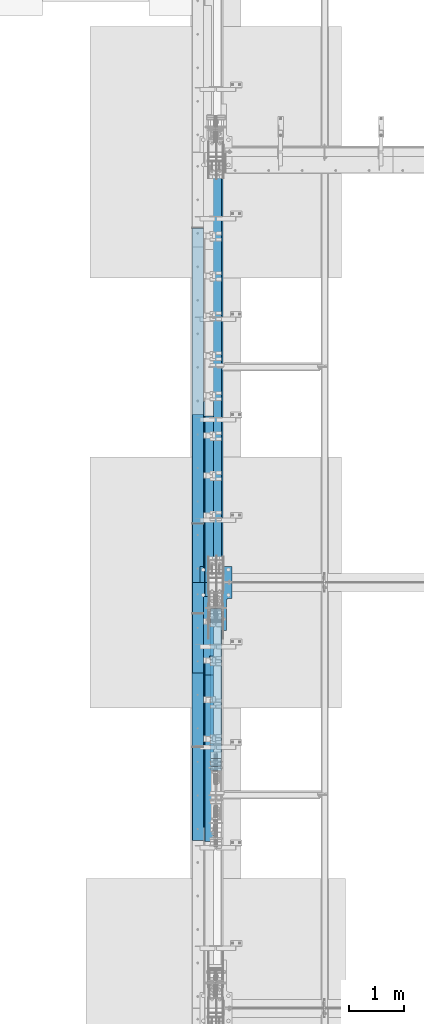
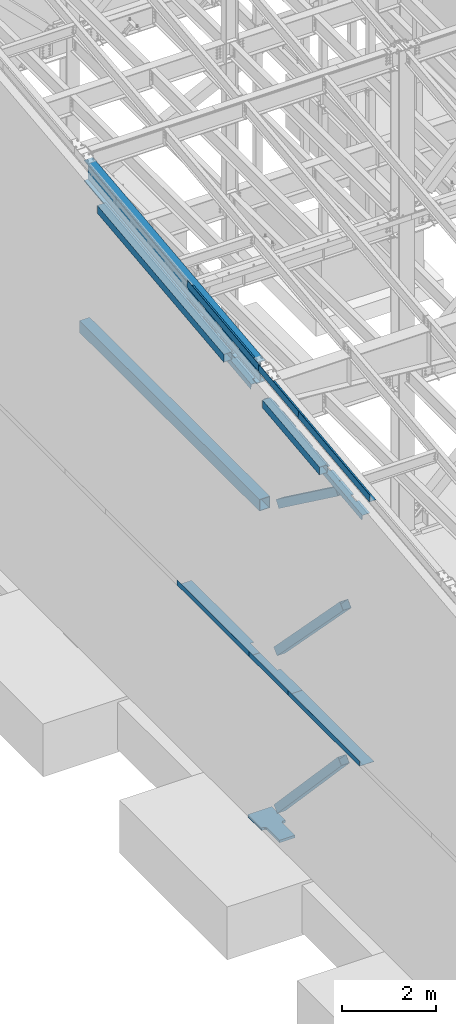
# One storey, part 725 of 1179: 14 beams, 3 members, 11 elements without a shape of their own.
"""IFC2X3 building model written with IfcOpenShell, lengths in millimetres."""

import ifcopenshell
import ifcopenshell.guid

model = None  # the IFC model being written
_history = None  # IfcOwnerHistory: only IFC2X3 demands one
_inside = {}  # id of a spatial element -> (the spatial element, [elements in it])
_under = {}  # id of a project, library or spatial element -> (it, [spatial elements below it])
_declared = {}  # id of a project -> (the project, [libraries it declares])
_typed = {}  # id of a type object -> (the type object, [elements of that type])
_made_of = {}  # id of a material, layer set ... -> (it, [elements and type objects made of it])


def new_model(schema):
    """Start an empty IFC model of exactly this schema.

    Asked for "IFC4X3", IfcOpenShell would pick the latest addendum, in which some entities
    have other attributes; the version numbers below select the first issue.
    IFC2X3 requires an IfcOwnerHistory on every rooted entity: one is made here for all.
    """
    global model, _history
    if schema == "IFC4X3":
        model = ifcopenshell.file(schema_version=(4, 3, 0, 0))
    else:
        model = ifcopenshell.file(schema=schema)
    _inside.clear()
    _under.clear()
    _declared.clear()
    _typed.clear()
    _made_of.clear()
    _history = None
    if model.schema == "IFC2X3":
        org = make("IfcOrganization", Name="unknown")
        user = make(
            "IfcPersonAndOrganization",
            ThePerson=make("IfcPerson", FamilyName="unknown"),
            TheOrganization=org,
        )
        app = make(
            "IfcApplication",
            ApplicationDeveloper=org,
            Version="unknown",
            ApplicationFullName="unknown",
            ApplicationIdentifier="unknown",
        )
        _history = make(
            "IfcOwnerHistory",
            OwningUser=user,
            OwningApplication=app,
            ChangeAction="ADDED",
            CreationDate=0,
        )
    return model


def make(cls, **values):
    """One entity of the class cls with the attributes given. An attribute that is None is left unset."""
    return model.create_entity(
        cls, **{name: value for name, value in values.items() if value is not None}
    )


def rooted(cls, **values):
    """An entity with a GlobalId (a new one), such as an element, a storey or a relation."""
    return make(cls, GlobalId=ifcopenshell.guid.new(), OwnerHistory=_history, **values)


def si_unit(unit_type, name, prefix=None):
    """IfcSIUnit, for example si_unit("LENGTHUNIT", "METRE", prefix="MILLI")."""
    return make("IfcSIUnit", UnitType=unit_type, Prefix=prefix, Name=name)


def assignment(units):
    """IfcUnitAssignment: the units of a project."""
    return None if units is None else make("IfcUnitAssignment", Units=units)


def point(xyz):
    """IfcCartesianPoint."""
    return None if xyz is None else make("IfcCartesianPoint", Coordinates=xyz)


def direction(xyz):
    """IfcDirection."""
    return None if xyz is None else make("IfcDirection", DirectionRatios=xyz)


def frame(location, z_axis=None, x_axis=None):
    """IfcAxis2Placement3D, a coordinate frame: its origin and axes. An axis left out is left unset."""
    return make(
        "IfcAxis2Placement3D",
        Location=point(location),
        Axis=direction(z_axis),
        RefDirection=direction(x_axis),
    )


def origin_with_axes():
    """The frame at (0, 0, 0) with the z axis (0, 0, 1) and the x axis (1, 0, 0) written out."""
    return frame((0.0, 0.0, 0.0), z_axis=(0.0, 0.0, 1.0), x_axis=(1.0, 0.0, 0.0))


def place(relative_to, where):
    """IfcLocalPlacement: puts the frame where relative to a parent placement (None: the world)."""
    return make(
        "IfcLocalPlacement", PlacementRelTo=relative_to, RelativePlacement=where
    )


def context(
    kind, dimensions, precision=None, world=None, true_north=None, identifier=None
):
    """IfcGeometricRepresentationContext, for example the 3D "Model" context."""
    return make(
        "IfcGeometricRepresentationContext",
        ContextIdentifier=identifier,
        ContextType=kind,
        CoordinateSpaceDimension=dimensions,
        Precision=precision,
        WorldCoordinateSystem=world,
        TrueNorth=true_north,
    )


def subcontext(parent, identifier, kind, view, scale=None):
    """IfcGeometricRepresentationSubContext, for example "Body" below "Model"."""
    return make(
        "IfcGeometricRepresentationSubContext",
        ContextIdentifier=identifier,
        ContextType=kind,
        ParentContext=parent,
        TargetScale=scale,
        TargetView=view,
    )


def project(units=None, contexts=None):
    """IfcProject with its units and contexts."""
    return rooted(
        "IfcProject",
        Name="project",
        RepresentationContexts=contexts,
        UnitsInContext=assignment(units),
    )


def spatial(cls, under=None, at=None, **own):
    """A site, building, storey or space (cls), placed at a placement, below another one or the project."""
    s = rooted(cls, ObjectPlacement=at, **own)
    if under is not None:
        _under.setdefault(under.id(), (under, []))[1].append(s)
    return s


def faces_of(points, faces, orient=None, outer=None):
    """IfcFace entities. A face is a list of loops; a loop is a list of indices into points, from 0.

    orient and outer hold one flag for each loop. By default every Orientation is true, the
    first loop of a face is its IfcFaceOuterBound and the others are IfcFaceBound.
    """
    made = []
    for i, loops in enumerate(faces):
        bounds = []
        for j, loop in enumerate(loops):
            is_outer = j == 0 if outer is None else outer[i][j]
            bounds.append(
                make(
                    "IfcFaceOuterBound" if is_outer else "IfcFaceBound",
                    Bound=make("IfcPolyLoop", Polygon=[points[k] for k in loop]),
                    Orientation=True if orient is None else orient[i][j],
                )
            )
        made.append(make("IfcFace", Bounds=bounds))
    return made


def faceted_brep(points, faces, orient=None, outer=None, voids=None):
    """IfcFacetedBrep: a solid bounded by flat faces; with voids (closed shells), ...WithVoids."""
    shared = [point(p) for p in points]
    hull = make("IfcClosedShell", CfsFaces=faces_of(shared, faces, orient, outer))
    if voids is None:
        return make("IfcFacetedBrep", Outer=hull)
    return make(
        "IfcFacetedBrepWithVoids",
        Outer=hull,
        Voids=[
            make(cls, CfsFaces=faces_of(shared, fs, o, b)) for cls, fs, o, b in voids
        ],
    )


def shape(context_of_items, identifier, shape_type, items):
    """IfcShapeRepresentation: the items that make up one representation, for example the "Body"."""
    return make(
        "IfcShapeRepresentation",
        ContextOfItems=context_of_items,
        RepresentationIdentifier=identifier,
        RepresentationType=shape_type,
        Items=items,
    )


def material(Name=None, Category=None):
    """IfcMaterial."""
    return make("IfcMaterial", Name=Name, Category=Category)


def made_of(thing, what):
    """Note that an element or type object is made of a material, layer set ...; save() writes the relation."""
    if what is not None:
        _made_of.setdefault(what.id(), (what, []))[1].append(thing)
    return thing


def type_object(cls, material=None, **own):
    """A type object (cls), such as IfcWallType, which elements share."""
    return made_of(rooted(cls, **own), material)


def element(
    cls,
    number,
    at=None,
    inside=None,
    cuts=None,
    type_object=None,
    material=None,
    context=None,
    identifier="Body",
    shape_type=None,
    held_by="IfcProductDefinitionShape",
    body=None,
    shapes=None,
    **own,
):
    """One element of the class cls, such as IfcWall. Its Tag is "e" and its number.

    at: its placement. inside: the storey or other place that contains it. cuts: it is an
    opening in that element (IfcRelVoidsElement). A single representation is given by context,
    identifier, shape_type and body (its items); several are given by shapes. held_by: the class
    of the entity that holds the representations. save() writes the other relations.
    """
    e = rooted(cls, Tag="e%d" % number, ObjectPlacement=at, **own)
    if body is not None:
        shapes = [shape(context, identifier, shape_type, body)]
    if shapes is not None:
        e.Representation = make(held_by, Representations=shapes)
    if inside is not None:
        _inside.setdefault(inside.id(), (inside, []))[1].append(e)
    if cuts is not None:
        rooted(
            "IfcRelVoidsElement", RelatingBuildingElement=cuts, RelatedOpeningElement=e
        )
    if type_object is not None:
        _typed.setdefault(type_object.id(), (type_object, []))[1].append(e)
    return made_of(e, material)


def aggregate(whole, parts):
    """IfcRelAggregates: a whole, such as a stair, and the parts it consists of."""
    return rooted("IfcRelAggregates", RelatingObject=whole, RelatedObjects=parts)


def save(model, path):
    """Write the relations noted so far, then the file.

    IfcRelAggregates (storeys below a building ...), IfcRelContainedInSpatialStructure (elements
    in a storey), IfcRelDefinesByType, IfcRelAssociatesMaterial and IfcRelDeclares: one each for
    every whole, place, type object, material and project.
    """
    for whole, parts in _under.values():
        aggregate(whole, parts)
    for where, things in _inside.values():
        rooted(
            "IfcRelContainedInSpatialStructure",
            RelatedElements=things,
            RelatingStructure=where,
        )
    for kind, things in _typed.values():
        rooted("IfcRelDefinesByType", RelatedObjects=things, RelatingType=kind)
    for what, things in _made_of.values():
        rooted("IfcRelAssociatesMaterial", RelatedObjects=things, RelatingMaterial=what)
    for by, libraries in _declared.values():
        rooted("IfcRelDeclares", RelatingContext=by, RelatedDefinitions=libraries)
    model.write(path)


model = new_model("IFC2X3")

# Units and contexts
model_context = context("Model", 3, precision=1e-05, world=origin_with_axes())
body_context = subcontext(model_context, "Body", "Model", "MODEL_VIEW")
ifc_project = project(units=[si_unit("LENGTHUNIT", "METRE", prefix="MILLI"), si_unit("AREAUNIT", "SQUARE_METRE"), si_unit("VOLUMEUNIT", "CUBIC_METRE"), si_unit("MASSUNIT", "GRAM", prefix="KILO"), si_unit("TIMEUNIT", "SECOND"), si_unit("PLANEANGLEUNIT", "RADIAN"), si_unit("SOLIDANGLEUNIT", "STERADIAN"), si_unit("THERMODYNAMICTEMPERATUREUNIT", "DEGREE_CELSIUS"), si_unit("LUMINOUSINTENSITYUNIT", "LUMEN")], contexts=[model_context])

# Site, building, storey
site_placement = place(None, origin_with_axes())
site = spatial("IfcSite", under=ifc_project, at=site_placement, CompositionType="ELEMENT")
building_placement = place(site_placement, origin_with_axes())
building = spatial("IfcBuilding", under=site, at=building_placement, Name="Undefined", CompositionType="ELEMENT")
storey_placement = place(building_placement, origin_with_axes())
storey = spatial("IfcBuildingStorey", under=building, at=storey_placement, Name="Undefined", CompositionType="ELEMENT", Elevation=0.0)

# Assembly, beam
assembly_1_placement = place(storey_placement, origin_with_axes())
assembly_1 = element("IfcElementAssembly", 1, at=assembly_1_placement, inside=storey, Name="BEAM", AssemblyPlace="NOTDEFINED", PredefinedType="RIGID_FRAME")
ifc_material_1 = material(Name="STEEL/A36")
beam_type_1 = type_object("IfcBeamType", PredefinedType="NOTDEFINED")
beam_1_placement = place(assembly_1_placement, frame((388.937000000002, 20744.8759537219, 11594.2188079249), z_axis=(0.0, -0.993676146336441, -0.112284087038017), x_axis=(-1.0, 0.0, 0.0)))
beam_1 = element("IfcBeam", 2, at=beam_1_placement, type_object=beam_type_1, material=ifc_material_1, Name="BENT_PLATE", context=body_context, shape_type="Brep", body=[
    faceted_brep([(71.4367508136392, -3.17500000044674, 1106.32825658341), (71.4367849309066, 3.1552417119201, 1106.32795884977), (0.0, 3.17499999954998, 1106.32798145128), (0.0, -3.17500000044674, 1106.32827920303), (71.4368115209303, -3.17499997041341, 1524.00064213012), (71.4368436902772, 3.174999999379, 1523.99999999914), (153.98700000004, -3.17499999938263, -1523.99999999915), (0.0, -3.17499999999927, -1524.0), (0.0, 3.17499999999927, -1524.0), (160.33700000004, 3.17500000061409, -1523.99999999915), (160.337000000008, -187.324999998866, -1523.99999999923), (153.987000000008, -187.324999998866, -1523.99999999923), (160.336999999976, 3.174999999379, 1523.99999999915), (160.337000000008, -187.325000000099, 1523.99999999907), (153.987000000008, -187.325000000099, 1523.99999999907), (153.986999999976, -3.17500000061773, 1523.99999999914)], [[[0, 1, 2, 3]], [[4, 5, 1, 0]], [[6, 7, 8, 9, 10, 11]], [[9, 12, 13, 10]], [[14, 11, 10, 13]], [[15, 6, 11, 14]], [[3, 7, 6, 15, 4, 0]], [[8, 7, 3, 2]], [[12, 9, 8, 2, 1, 5]], [[15, 14, 13, 12, 5, 4]]]),
])

# Assembly, beams
assembly_2_placement = place(storey_placement, origin_with_axes())
assembly_2 = element("IfcElementAssembly", 3, at=assembly_2_placement, inside=storey, Name="BEAM", AssemblyPlace="NOTDEFINED", PredefinedType="RIGID_FRAME")
beam_2_placement = place(assembly_2_placement, frame((388.937000043229, 18382.5389240182, 11327.277855736), z_axis=(0.0, -0.993676146336441, -0.112284087038017), x_axis=(-1.0, 0.0, 0.0)))
beam_2 = element("IfcBeam", 4, at=beam_2_placement, type_object=beam_type_1, material=ifc_material_1, Name="BENT_PLATE", context=body_context, shape_type="Brep", body=[
    faceted_brep([(71.4368100497966, -3.17499999982647, -431.111032670688), (71.4368442882297, 3.17447798306421, -431.11102991645), (71.4367344368292, 3.17500000033942, -846.931499999526), (71.4367001974234, -3.1749999996573, -846.931499999529), (5.00222085975111e-12, -3.17499999982647, -431.111009274173), (5.00222085975111e-12, 3.17500000017026, -431.111006519772), (160.336999998218, 3.17499999965366, 846.931499999526), (-9.77706804405898e-12, 3.17499999965366, 846.931499999522), (-9.77706804405898e-12, -3.17500000034306, 846.931499999522), (153.986999998218, -3.17500000034306, 846.931499999522), (153.986999998236, -187.324999998071, 846.931499999449), (160.336999998236, -187.324999998071, 846.931499999449), (160.336999998254, 3.17500000033942, -846.931499999522), (160.336999998236, -187.324999997387, -846.931499999599), (153.986999998236, -187.324999997387, -846.931499999599), (153.986999998254, -3.1749999996573, -846.931499999529)], [[[0, 1, 2, 3]], [[4, 5, 1, 0]], [[6, 7, 8, 9, 10, 11]], [[12, 6, 11, 13]], [[10, 14, 13, 11]], [[9, 15, 14, 10]], [[12, 13, 14, 15, 3, 2]], [[7, 6, 12, 2, 1, 5]], [[8, 7, 5, 4]], [[15, 9, 8, 4, 0, 3]]]),
])
beam_3_placement = place(assembly_2_placement, frame((388.937000000002, 16026.6008477543, 11061.0599768286), z_axis=(0.0, -0.993676146336441, -0.112284087038017), x_axis=(-1.0, 0.0, 0.0)))
beam_3 = element("IfcBeam", 5, at=beam_3_placement, type_object=beam_type_1, material=ifc_material_1, Name="BENT_PLATE", context=body_context, shape_type="Brep", body=[
    faceted_brep([(0.0, -3.17499999999927, -1524.0), (6.00266503170133e-10, -3.17499999922438, 1524.00000000052), (6.00266503170133e-10, 3.17500000077416, 1524.00000000052), (0.0, 3.17499999999927, -1524.0), (160.336999999976, 3.174999999379, 1523.99999999915), (160.33700000004, 3.17500000061409, -1523.99999999915), (153.98700000004, -3.17499999938263, -1523.99999999915), (153.986999999976, -3.17500000061773, 1523.99999999914), (160.337000000008, -187.325000000099, 1523.99999999907), (160.337000000008, -187.324999998866, -1523.99999999923), (153.987000000008, -187.325000000099, 1523.99999999907), (153.987000000008, -187.324999998866, -1523.99999999923)], [[[0, 1, 2, 3]], [[3, 2, 4, 5]], [[1, 0, 6, 7]], [[5, 4, 8, 9]], [[4, 2, 1, 7, 10, 8]], [[7, 6, 11, 10]], [[6, 0, 3, 5, 9, 11]], [[10, 11, 9, 8]]]),
])

# Assembly, member
assembly_3_placement = place(storey_placement, origin_with_axes())
assembly_3 = element("IfcElementAssembly", 6, at=assembly_3_placement, inside=storey, Name="None", AssemblyPlace="NOTDEFINED", PredefinedType="RIGID_FRAME")
ifc_material_2 = material(Name="STEEL/A992")
member_type = type_object("IfcMemberType", Name="HSS8X8X3/16", PredefinedType="NOTDEFINED")
member_1_placement = place(assembly_3_placement, frame((431.800000000002, 18595.6807195261, 8325.44875404219), z_axis=(-1.0, 0.0, 0.0), x_axis=(0.0, -0.806043266248582, 0.591856615182527)))
member_1 = element("IfcMember", 7, at=member_1_placement, type_object=member_type, material=ifc_material_2, Name="None", ObjectType="HSS8X8X3/16", context=body_context, shape_type="Brep", body=[
    faceted_brep([(-3.63797880709171e-12, 96.8374999999978, -96.8375000000015), (-3.63797880709171e-12, -96.8374999999978, -96.8375000000015), (3111.50000002446, -96.8375000002598, -96.8375), (3111.50000002456, 96.8374999994812, -96.8375), (-3.63797880709171e-12, -96.8374999999978, 96.8375000000015), (3111.50000002446, -96.8375000002598, 96.8375), (-3.63797880709171e-12, 96.8374999999978, 96.8375000000015), (3111.50000002456, 96.8374999994812, 96.8375), (-3.63797880709171e-12, 101.599999999999, -101.599999999999), (-3.63797880709171e-12, 101.599999999999, 101.599999999999), (3111.50000002456, 101.599999999471, 101.6), (3111.50000002456, 101.599999999471, -101.6), (0.0, -101.599999999999, 101.599999999999), (3111.50000002446, -101.600000000253, 101.6), (0.0, -101.599999999999, -101.599999999999), (3111.50000002446, -101.600000000253, -101.6)], [[[0, 1, 2, 3]], [[1, 4, 5, 2]], [[4, 6, 7, 5]], [[6, 0, 3, 7]], [[8, 9, 10, 11]], [[9, 12, 13, 10]], [[12, 14, 15, 13]], [[14, 8, 11, 15]], [[13, 15, 11, 10], [5, 7, 3, 2]], [[14, 12, 9, 8], [6, 4, 1, 0]]]),
])
aggregate(assembly_3, [member_1])

assembly_4_placement = place(storey_placement, origin_with_axes())
assembly_4 = element("IfcElementAssembly", 8, at=assembly_4_placement, inside=storey, Name="None", AssemblyPlace="NOTDEFINED", PredefinedType="RIGID_FRAME")
member_2_placement = place(assembly_4_placement, frame((431.800000000002, 18683.9850517779, 4449.73744761525), z_axis=(-1.0, 0.0, 0.0), x_axis=(0.0, -0.69846692303685, 0.715642339037759)))
member_2 = element("IfcMember", 9, at=member_2_placement, type_object=member_type, material=ifc_material_2, Name="None", ObjectType="HSS8X8X3/16", context=body_context, shape_type="Brep", body=[
    faceted_brep([(-3.63797880709171e-12, 96.8374999999978, -96.8375000000015), (-3.63797880709171e-12, -96.8374999999978, -96.8375000000015), (4020.12294193522, -96.8374999996613, -96.8375), (4020.12294193534, 96.8375000002416, -96.8375), (-3.63797880709171e-12, -96.8374999999978, 96.8375000000015), (4020.12294193522, -96.8374999996613, 96.8375), (-3.63797880709171e-12, 96.8374999999978, 96.8375000000015), (4020.12294193534, 96.8375000002416, 96.8375), (-3.63797880709171e-12, 101.599999999999, -101.599999999999), (-3.63797880709171e-12, 101.599999999999, 101.599999999999), (4020.12294193534, 101.600000000239, 101.6), (4020.12294193534, 101.600000000239, -101.6), (0.0, -101.599999999999, 101.599999999999), (4020.12294193522, -101.59999999966, 101.6), (0.0, -101.599999999999, -101.599999999999), (4020.12294193522, -101.59999999966, -101.6)], [[[0, 1, 2, 3]], [[1, 4, 5, 2]], [[4, 6, 7, 5]], [[6, 0, 3, 7]], [[8, 9, 10, 11]], [[9, 12, 13, 10]], [[12, 14, 15, 13]], [[14, 8, 11, 15]], [[13, 15, 11, 10], [5, 7, 3, 2]], [[14, 12, 9, 8], [6, 4, 1, 0]]]),
])
aggregate(assembly_4, [member_2])

assembly_5_placement = place(storey_placement, origin_with_axes())
assembly_5 = element("IfcElementAssembly", 10, at=assembly_5_placement, inside=storey, Name="None", AssemblyPlace="NOTDEFINED", PredefinedType="RIGID_FRAME")
member_3_placement = place(assembly_5_placement, frame((431.800000000002, 18676.0263469619, 369.341890443129), z_axis=(-1.0, 0.0, 0.0), x_axis=(0.0, -0.68599585875867, 0.727605443744036)))
member_3 = element("IfcMember", 11, at=member_3_placement, type_object=member_type, material=ifc_material_2, Name="None", ObjectType="HSS8X8X3/16", context=body_context, shape_type="Brep", body=[
    faceted_brep([(-3.63797880709171e-12, 96.8374999999978, -96.8375000000015), (-3.63797880709171e-12, -96.8374999999978, -96.8375000000015), (3968.75000001255, -96.8375000016003, -96.8375), (3968.75000001275, 96.8374999981806, -96.8375), (-3.63797880709171e-12, -96.8374999999978, 96.8375000000015), (3968.75000001255, -96.8375000016003, 96.8375), (-3.63797880709171e-12, 96.8374999999978, 96.8375000000015), (3968.75000001275, 96.8374999981806, 96.8375), (-3.63797880709171e-12, 101.599999999999, -101.599999999999), (-3.63797880709171e-12, 101.599999999999, 101.599999999999), (3968.75000001276, 101.599999998176, 101.6), (3968.75000001276, 101.599999998176, -101.6), (0.0, -101.599999999999, 101.599999999999), (3968.75000001255, -101.600000001596, 101.6), (0.0, -101.599999999999, -101.599999999999), (3968.75000001255, -101.600000001596, -101.6)], [[[0, 1, 2, 3]], [[1, 4, 5, 2]], [[4, 6, 7, 5]], [[6, 0, 3, 7]], [[8, 9, 10, 11]], [[9, 12, 13, 10]], [[12, 14, 15, 13]], [[14, 8, 11, 15]], [[13, 15, 11, 10], [5, 7, 3, 2]], [[14, 12, 9, 8], [6, 4, 1, 0]]]),
])
aggregate(assembly_5, [member_3])

# Beam
beam_type_2 = type_object("IfcBeamType", PredefinedType="NOTDEFINED")
beam_4_placement = place(assembly_2_placement, frame((388.937000044923, 18384.1942772865, 10798.6583136634), z_axis=(0.0, -0.993676146336441, -0.112284087038017), x_axis=(-1.0, 0.0, 0.0)))
beam_4 = element("IfcBeam", 12, at=beam_4_placement, type_object=beam_type_2, material=ifc_material_1, Name="BENT_PLATE", context=body_context, shape_type="Brep", body=[
    faceted_brep([(76.1995000443338, -3.24670956239788, -219.626464554756), (76.1995000443338, 3.1039040513424, -219.626464557288), (-3.63797880709171e-12, 3.17499999991014, -219.626464576591), (-3.63797880709171e-12, -3.17500000008658, -219.626464579123), (76.1995000443338, -3.24623678174794, -86.2764645749012), (76.1995000443338, 3.1043768319887, -86.2764645773823), (0.0, -3.17500000003201, -86.276464595765), (0.0, 3.17499999996653, -86.2764645932875), (76.1995000443338, -3.24670956267983, 496.539599803236), (76.1995000443338, 3.10390405105863, 496.539599800701), (4.71800376544707e-12, 3.17499999979373, 496.539599800701), (5.17275111633353e-12, -3.17500000020118, 496.539599803233), (76.1995000443338, -3.2463818854485, 588.962500252739), (76.1995000453862, 3.1750000002321, 588.962499999663), (185.737000044118, -3.17500000022483, 588.962499999659), (185.737000044106, 136.524388119697, 588.962499999718), (179.387000044106, 136.524388119697, 588.962499999718), (179.387000044118, 3.1749999997719, 588.962499999663), (179.387000044091, 3.17500000024847, -588.962499999678), (179.387000044106, 136.524388120175, -588.962499999627), (185.737000044106, 136.524388120175, -588.962499999627), (185.737000044091, -3.17499999974643, -588.962499999681), (76.1995000450988, -3.1750000002412, -588.96249999967), (76.1995000450988, 3.17499999975553, -588.962499999674), (76.1995000443338, -3.17449425640189, -442.912500015456), (76.1995000443338, 3.17611935734749, -442.912500017934), (-3.63797880709171e-12, -3.17500000017753, -442.912500018174), (-3.63797880709171e-12, 3.17499999982101, -442.912500015696)], [[[0, 1, 2, 3]], [[4, 5, 1, 0]], [[6, 7, 5, 4]], [[8, 9, 10, 11]], [[12, 13, 9, 8]], [[14, 15, 16, 17, 13, 12]], [[18, 17, 16, 19]], [[15, 20, 19, 16]], [[14, 21, 20, 15]], [[18, 19, 20, 21, 22, 23]], [[24, 25, 23, 22]], [[26, 27, 25, 24]], [[3, 2, 27, 26]], [[10, 9, 13, 17, 18, 23, 25, 27, 2, 1, 5, 7]], [[11, 10, 7, 6]], [[3, 26, 24, 22, 21, 14, 12, 8, 11, 6, 4, 0]]]),
])

beam_5_placement = place(assembly_2_placement, frame((388.93700014231, 16284.5938429571, 10561.4062480502), z_axis=(0.0, -0.993676146336441, -0.112284087038017), x_axis=(-1.0, 0.0, 0.0)))
beam_5 = element("IfcBeam", 13, at=beam_5_placement, type_object=beam_type_2, material=ifc_material_1, Name="BENT_PLATE", context=body_context, shape_type="Brep", body=[
    faceted_brep([(76.1995001419065, -3.17561361394473, 322.886542456738), (76.1995001419065, 3.17499999987376, 322.886542456734), (-3.46744855050929e-12, 3.17499999986285, 322.886542456734), (-2.95585778076202e-12, -3.17500000013206, 322.886542456738), (76.1995001419065, -3.17561361395019, 338.761542456545), (76.1995001419065, 3.17499999986831, 338.761542456567), (-3.12638803734444e-12, -3.17500000013933, 338.761542456548), (-3.63797880709171e-12, 3.17499999985921, 338.761542456567), (76.1995001418678, -3.17502209167469, 843.8496355311), (76.1995001418678, 3.17559152219837, 843.849635530467), (-8.64019966684282e-12, 3.17499999965366, 843.849635530467), (-8.18545231595635e-12, -3.17500000034306, 843.8496355311), (76.1995001418678, -3.17448036747373, 1063.38482136756), (76.1995001418678, 3.17613324639024, 1063.38482136694), (-1.03455022326671e-11, -3.17500000043219, 1063.38482136756), (-1.08570930024143e-11, 3.17499999956271, 1063.38482136694), (6.00266503170133e-10, -3.17499999922438, 1524.00000000052), (6.00266503170133e-10, 3.17500000077416, 1524.00000000052), (179.387000203274, 3.1749999978274, 1523.9999999998), (185.737000203274, -3.17500000222026, 1523.9999999998), (185.73700022686, 136.52438794029, 1523.9999999992), (179.387000226859, 136.52438794029, 1523.9999999992), (179.387000201926, 3.17499999921893, -1523.99999999987), (179.387000226859, 136.524387941527, -1523.99999999909), (185.73700022686, 136.524387941527, -1523.99999999909), (185.737000201926, -3.17500000083055, -1523.99999999987), (76.1995001437463, -3.17500000061955, -1523.99999999915), (76.1995001437463, 3.17499999937536, -1523.99999999915), (76.199500141927, -3.2462371376223, -1483.07290022639), (76.199500141927, 3.10437647609979, -1483.07290022991), (0.0, -3.17500000059772, -1483.07290022308), (0.0, 3.17499999939719, -1483.0729002206), (0.0, -3.17500000036125, -900.256835867101), (0.0, 3.17499999963366, -900.256835866643), (76.199500141927, -3.24670991849416, -900.256835854045), (76.199500141927, 3.10390369522793, -900.256835857617), (76.199500141927, -3.24623713791152, -766.906835871378), (76.199500141927, 3.10437647581057, -766.906835874899), (0.0, -3.17500000030668, -766.90683588271), (0.0, 3.17499999968823, -766.90683588231), (0.0, -3.17500000007203, -184.090771515868), (0.0, 3.17499999992469, -184.090771515392), (76.199500141927, -3.24670991874882, -184.090771494692), (76.199500141927, 3.10390369497327, -184.090771498268), (76.199500141927, -3.24623713819346, -50.7407715117843), (76.199500141927, 3.10437647553044, -50.7407715153095), (0.0, -3.17500000001564, -50.740771531473), (0.0, 3.17499999997926, -50.7407715310619)], [[[0, 1, 2, 3]], [[4, 5, 1, 0]], [[6, 7, 5, 4]], [[8, 9, 10, 11]], [[12, 13, 9, 8]], [[14, 15, 13, 12]], [[16, 17, 15, 14]], [[18, 17, 16, 19, 20, 21]], [[22, 18, 21, 23]], [[20, 24, 23, 21]], [[19, 25, 24, 20]], [[22, 23, 24, 25, 26, 27]], [[28, 29, 27, 26]], [[30, 31, 29, 28]], [[32, 33, 31, 30]], [[34, 35, 33, 32]], [[36, 37, 35, 34]], [[38, 39, 37, 36]], [[39, 38, 40, 41]], [[42, 43, 41, 40]], [[44, 45, 43, 42]], [[46, 47, 45, 44]], [[47, 46, 3, 2]], [[10, 9, 13, 15, 17, 18, 22, 27, 29, 31, 33, 35, 37, 39, 41, 43, 45, 47, 2, 1, 5, 7]], [[11, 10, 7, 6]], [[3, 46, 44, 42, 40, 38, 36, 34, 32, 30, 28, 26, 25, 19, 16, 14, 12, 8, 11, 6, 4, 0]]]),
])

aggregate(assembly_2, [beam_2, beam_4, beam_5, beam_3])

beam_6_placement = place(assembly_1_placement, frame((388.937000226112, 21002.8689489845, 11094.5656952366), z_axis=(0.0, -0.993676146336441, -0.112284087038017), x_axis=(-1.0, 0.0, 0.0)))
beam_6 = element("IfcBeam", 14, at=beam_6_placement, type_object=beam_type_2, material=ifc_material_1, Name="BENT_PLATE", context=body_context, shape_type="Brep", body=[
    faceted_brep([(76.1995001797359, -3.17550574784764, 1377.95000001703), (76.1995001797359, 3.17510786590537, 1377.95000001449), (7.27595761418343e-12, 3.17500000055588, 1377.94999996396), (7.27595761418343e-12, -3.1749999994372, 1377.94999996142), (76.1995001797359, -3.1750000051652, 1524.00000000082), (76.1995002269396, 3.17500000061045, 1523.99999999914), (1.13686837721616e-13, -3.17500000024665, 609.233168208913), (-1.13686837721616e-13, 3.17499999975189, 609.2331682064), (76.1995002255223, 3.08849412972631, 609.233168206403), (76.1995002255223, -3.26211948402488, 609.233168208917), (76.1995002255223, 3.08802137014754, 472.708168222805), (76.1995002255223, -3.26259224360183, 472.708168225359), (-1.13686837721616e-13, 3.17499999980464, 472.708168222802), (1.13686837721616e-13, -3.17500000019027, 472.708168225363), (-1.13686837721616e-13, 3.17500000004657, -121.293295540163), (1.13686837721616e-13, -3.17499999995016, -121.293295537649), (76.1995002255636, 3.08849413003009, -121.293295540163), (76.1995002255636, -3.26211948372111, -121.293295537653), (76.1995002255636, 3.0880213704495, -257.818295523761), (76.1995002255636, -3.2625922433017, -257.818295521203), (-1.13686837721616e-13, 3.17500000010114, -257.818295523764), (1.13686837721616e-13, -3.17499999989377, -257.818295521203), (-1.13686837721616e-13, 3.17500000034306, -851.819759286736), (1.13686837721616e-13, -3.17499999965366, -851.819759284226), (76.1995002256049, 3.08849413032476, -851.819759286736), (76.1995002256049, -3.26211948342643, -851.819759284226), (76.1995002256049, 3.08802137074599, -988.344759270341), (76.1995002256049, -3.26259224300702, -988.34475926778), (-1.13686837721616e-13, 3.17500000039763, -988.344759270334), (1.13686837721616e-13, -3.17499999959909, -988.344759267777), (0.0, 3.17499999999927, -1524.0), (0.0, -3.17499999999927, -1524.0), (185.737000201926, -3.17500000083055, -1523.99999999987), (179.387000201926, 3.17499999921893, -1523.99999999987), (179.387000202255, 136.524999793486, -1523.99999999991), (185.737000202255, 136.524999793486, -1523.99999999991), (179.387000203274, 3.1749999978274, 1523.9999999998), (179.387000202948, 136.524999792875, 1523.99999999976), (185.737000202948, 136.524999792873, 1523.99999999976), (185.737000203274, -3.17500000222026, 1523.9999999998)], [[[0, 1, 2, 3]], [[4, 5, 1, 0]], [[6, 7, 8, 9]], [[9, 8, 10, 11]], [[11, 10, 12, 13]], [[13, 12, 14, 15]], [[15, 14, 16, 17]], [[17, 16, 18, 19]], [[19, 18, 20, 21]], [[21, 20, 22, 23]], [[23, 22, 24, 25]], [[25, 24, 26, 27]], [[27, 26, 28, 29]], [[30, 31, 29, 28]], [[32, 31, 30, 33, 34, 35]], [[33, 36, 37, 34]], [[38, 35, 34, 37]], [[39, 32, 35, 38]], [[3, 6, 9, 11, 13, 15, 17, 19, 21, 23, 25, 27, 29, 31, 32, 39, 4, 0]], [[7, 6, 3, 2]], [[36, 33, 30, 28, 26, 24, 22, 20, 18, 16, 14, 12, 10, 8, 7, 2, 1, 5]], [[39, 38, 37, 36, 5, 4]]]),
])

# Assembly, beam
assembly_6_placement = place(storey_placement, origin_with_axes())
assembly_6 = element("IfcElementAssembly", 15, at=assembly_6_placement, inside=storey, Name="BEAM", AssemblyPlace="NOTDEFINED", PredefinedType="RIGID_FRAME")
beam_type_3 = type_object("IfcBeamType", PredefinedType="NOTDEFINED")
beam_7_placement = place(assembly_6_placement, frame((352.424987792969, 20754.975, 4105.275), z_axis=(0.0, -1.0, 0.0), x_axis=(-1.0, 0.0, 0.0)))
beam_7 = element("IfcBeam", 16, at=beam_7_placement, type_object=beam_type_3, material=ifc_material_1, Name="BENT_PLATE", context=body_context, shape_type="Brep", body=[
    faceted_brep([(84.1374893188477, -3.17500000000018, 1120.775), (84.1374893188477, 3.17500000000018, 1120.775), (0.0, 3.17500000000018, 1120.775), (0.0, -3.17500000000018, 1120.775), (84.1374893188477, -3.17500000000018, 1524.0), (84.1374893188477, 3.17500000000018, 1524.0), (346.074987792969, -3.17500000000109, -1524.0), (0.0, -3.17499999999927, -1524.0), (0.0, 3.17499999999927, -1524.0), (352.424987792969, 3.17499999999927, -1524.0), (352.424987792969, -130.175006103515, -1524.0), (346.074987792969, -130.175006103515, -1524.0), (352.424987792969, 3.17499999999927, 1524.0), (352.424987792969, -130.175006103515, 1524.0), (346.074987792969, -130.175006103515, 1524.0), (346.074987792969, -3.17500000000109, 1524.0)], [[[0, 1, 2, 3]], [[4, 5, 1, 0]], [[6, 7, 8, 9, 10, 11]], [[9, 12, 13, 10]], [[14, 11, 10, 13]], [[15, 6, 11, 14]], [[3, 7, 6, 15, 4, 0]], [[8, 7, 3, 2]], [[12, 9, 8, 2, 1, 5]], [[15, 14, 13, 12, 5, 4]]]),
])
aggregate(assembly_6, [beam_7])

# Assembly, beams
assembly_7_placement = place(storey_placement, origin_with_axes())
assembly_7 = element("IfcElementAssembly", 17, at=assembly_7_placement, inside=storey, Name="BEAM", AssemblyPlace="NOTDEFINED", PredefinedType="RIGID_FRAME")
beam_8_placement = place(assembly_7_placement, frame((352.424987792969, 18402.3, 4105.275), z_axis=(0.0, -1.0, 0.0), x_axis=(-1.0, 0.0, 0.0)))
beam_8 = element("IfcBeam", 18, at=beam_8_placement, type_object=beam_type_3, material=ifc_material_1, Name="BENT_PLATE", context=body_context, shape_type="Brep", body=[
    faceted_brep([(84.1374893188477, -3.17500000000018, -86.9758210736909), (84.1374893188477, 3.17500000000018, -86.9758210736909), (84.1374893188477, 3.17500000000018, -822.325000000001), (84.1374893188477, -3.17500000000018, -822.325000000001), (0.0, -3.17500000000018, -86.9758210736909), (0.0, 3.17500000000018, -86.9758210736909), (352.424987792969, 3.17499999999927, 822.325000000001), (0.0, 3.17500000000018, 822.325000000001), (0.0, -3.17500000000018, 822.325000000001), (346.074987792969, -3.17500000000109, 822.325000000001), (346.074987792969, -130.175006103515, 822.325000000001), (352.424987792969, -130.175006103515, 822.325000000001), (352.424987792969, 3.17499999999927, -822.325000000001), (352.424987792969, -130.175006103515, -822.325000000001), (346.074987792969, -130.175006103515, -822.325000000001), (346.074987792969, -3.17500000000109, -822.325000000001)], [[[0, 1, 2, 3]], [[4, 5, 1, 0]], [[6, 7, 8, 9, 10, 11]], [[12, 6, 11, 13]], [[10, 14, 13, 11]], [[9, 15, 14, 10]], [[12, 13, 14, 15, 3, 2]], [[7, 6, 12, 2, 1, 5]], [[8, 7, 5, 4]], [[15, 9, 8, 4, 0, 3]]]),
])
beam_9_placement = place(assembly_7_placement, frame((352.424987792969, 16055.975, 4105.275), z_axis=(0.0, -1.0, 0.0), x_axis=(-1.0, 0.0, 0.0)))
beam_9 = element("IfcBeam", 19, at=beam_9_placement, type_object=beam_type_3, material=ifc_material_1, Name="BENT_PLATE", context=body_context, shape_type="Brep", body=[
    faceted_brep([(0.0, -3.17499999999927, -1524.0), (6.00266503170133e-10, -3.17499999922438, 1524.00000000052), (6.00266503170133e-10, 3.17500000077416, 1524.00000000052), (0.0, 3.17499999999927, -1524.0), (352.424987792969, 3.17499999999927, 1524.0), (352.424987792969, 3.17499999999927, -1524.0), (346.074987792969, -3.17500000000109, -1524.0), (346.074987792969, -3.17500000000109, 1524.0), (352.424987792969, -130.175006103515, 1524.0), (352.424987792969, -130.175006103515, -1524.0), (346.074987792969, -130.175006103515, 1524.0), (346.074987792969, -130.175006103515, -1524.0)], [[[0, 1, 2, 3]], [[3, 2, 4, 5]], [[1, 0, 6, 7]], [[5, 4, 8, 9]], [[4, 2, 1, 7, 10, 8]], [[7, 6, 11, 10]], [[6, 0, 3, 5, 9, 11]], [[10, 11, 9, 8]]]),
])
aggregate(assembly_7, [beam_8, beam_9])

# Assembly, beam
assembly_8_placement = place(storey_placement, origin_with_axes())
assembly_8 = element("IfcElementAssembly", 20, at=assembly_8_placement, inside=storey, Name="BEAM", AssemblyPlace="NOTDEFINED", PredefinedType="RIGID_FRAME")
ifc_material_3 = material()
beam_type_4 = type_object("IfcBeamType", Name="HSS8X8X1/4", PredefinedType="NOTDEFINED")
beam_10_placement = place(assembly_8_placement, frame((101.599999999999, 16230.6, 10721.878317112), z_axis=(0.0, -0.112390436031377, 0.993664123277417), x_axis=(0.0, 0.993664123277417, 0.112390436031378)))
beam_10 = element("IfcBeam", 21, at=beam_10_placement, type_object=beam_type_4, material=ifc_material_3, Name="BEAM", ObjectType="HSS8X8X1/4", context=body_context, shape_type="Brep", body=[
    faceted_brep([(2459.04910080208, -101.6, 101.60000000143), (2459.04910080208, 101.6, 101.60000000143), (17.8821675096806, 101.6, 101.600000000077), (17.8821675096806, -101.6, 101.600000000077), (2436.06574448822, -101.6, -101.599999998713), (-5.10118880419031, -101.6, -101.600000000066), (2436.06574448822, 101.6, -101.599999998713), (-5.10118880419031, 101.6, -101.600000000066), (2458.33087091727, -95.25, 95.2500000014261), (2458.33087091727, 95.25, 95.2500000014261), (2436.78397437302, 95.25, -95.2499999987067), (2436.78397437302, -95.25, -95.2499999987067), (17.1639376248713, -95.25, 95.2500000000728), (17.1639376248713, 95.25, 95.2500000000728), (-4.38295891938105, 95.25, -95.2500000000637), (-4.38295891938105, -95.25, -95.2500000000637)], [[[0, 1, 2, 3]], [[4, 0, 3, 5]], [[6, 4, 5, 7]], [[1, 6, 7, 2]], [[0, 4, 6, 1], [8, 9, 10, 11]], [[9, 8, 12, 13]], [[10, 9, 13, 14]], [[11, 10, 14, 15]], [[8, 11, 15, 12]], [[7, 5, 3, 2], [14, 13, 12, 15]]]),
])
aggregate(assembly_8, [beam_10])

assembly_9_placement = place(storey_placement, origin_with_axes())
assembly_9 = element("IfcElementAssembly", 22, at=assembly_9_placement, inside=storey, Name="BEAM", AssemblyPlace="NOTDEFINED", PredefinedType="RIGID_FRAME")
beam_11_placement = place(assembly_9_placement, frame((101.599999999999, 20294.6000005405, 11181.5734429413), z_axis=(0.0, -0.112390436031377, 0.993664123277417), x_axis=(0.0, 0.993664123277417, 0.112390436031378)))
beam_11 = element("IfcBeam", 23, at=beam_11_placement, type_object=beam_type_4, material=ifc_material_3, Name="BEAM", ObjectType="HSS8X8X1/4", context=body_context, shape_type="Brep", body=[
    faceted_brep([(5424.23616062771, -101.6, 101.599999995657), (5424.23616062771, 101.6, 101.599999995657), (17.8821675096806, 101.6, 101.600000000077), (17.8821675096806, -101.6, 101.600000000077), (5401.25280410938, -101.6, -101.600000004199), (-5.10118880419031, -101.6, -101.600000000066), (5401.25280410938, 101.6, -101.600000004199), (-5.10118880419031, 101.6, -101.600000000066), (5423.51793073651, -95.25, 95.2499999956617), (5423.51793073651, 95.25, 95.2499999956617), (5401.97103400057, 95.25, -95.2500000042037), (5401.97103400057, -95.25, -95.2500000042037), (17.1639376248713, -95.25, 95.2500000000728), (17.1639376248713, 95.25, 95.2500000000728), (-4.38295891938105, 95.25, -95.2500000000637), (-4.38295891938105, -95.25, -95.2500000000637)], [[[0, 1, 2, 3]], [[4, 0, 3, 5]], [[6, 4, 5, 7]], [[1, 6, 7, 2]], [[0, 4, 6, 1], [8, 9, 10, 11]], [[9, 8, 12, 13]], [[10, 9, 13, 14]], [[11, 10, 14, 15]], [[8, 11, 15, 12]], [[7, 5, 3, 2], [14, 13, 12, 15]]]),
])
aggregate(assembly_9, [beam_11])

# Beam
beam_type_5 = type_object("IfcBeamType", Name="W21X93", PredefinedType="NOTDEFINED")
beam_12_placement = place(assembly_1_placement, frame((431.800000000002, 19258.6467562732, 11146.6963528441), z_axis=(0.0, -0.112284087038017, 0.993676146336441), x_axis=(0.0, 0.993676146336441, 0.112284087038017)))
beam_12 = element("IfcBeam", 24, at=beam_12_placement, type_object=beam_type_5, material=ifc_material_2, Name="BEAM", ObjectType="W21X93", context=body_context, shape_type="Brep", body=[
    faceted_brep([(199.930151815766, -106.362499999999, -274.637499999924), (199.930151815766, 106.362499999999, -274.637499999924), (7550.50158985777, 106.362499999999, -274.637500002909), (7550.50158985777, -106.362499999999, -274.637500002909), (202.620932743182, -106.362499999999, -250.824999999939), (202.620932743182, -7.14374999999927, -250.824999999939), (214.511782852391, -7.14375000000001, -145.595003258248), (259.165541301194, -7.14375000000001, 249.575637438327), (259.306717614098, -7.14374999999927, 250.824999999757), (259.306717614098, -106.362499999999, 250.824999999757), (261.997498541514, -106.362499999999, 274.637499999742), (261.997498541514, 106.362499999999, 274.637499999742), (259.306717614098, 106.362499999999, 250.824999999757), (259.306717614098, 7.14374999999927, 250.824999999757), (202.620932743182, 7.14374999999927, -250.824999999939), (202.620932743182, 106.362499999999, -250.824999999939), (7553.19237078519, -106.362499999999, -250.825000002924), (7553.19237078519, -7.14374999999927, -250.825000002924), (7559.19332913572, -7.14375000000001, -197.718550768866), (7603.84708758447, -7.14375000000001, 197.452089927256), (7609.8781556561, -7.14374999999927, 250.824999996772), (7609.8781556561, -106.362499999999, 250.824999996772), (7612.56893658352, -106.362499999999, 274.637499996757), (7612.56893658352, 106.362499999999, 274.637499996757), (7609.8781556561, 106.362499999999, 250.824999996772), (7609.8781556561, 7.14374999999927, 250.824999996772), (7553.19237078519, 7.14374999999927, -250.825000002924), (7553.19237078519, 106.362499999999, -250.825000002924)], [[[0, 1, 2, 3]], [[0, 4, 5, 6, 7, 8, 9, 10, 11, 12, 13, 14, 15, 1]], [[5, 4, 16, 17]], [[8, 7, 6, 5, 17, 18, 19, 20]], [[9, 8, 20, 21]], [[10, 9, 21, 22]], [[11, 10, 22, 23]], [[12, 11, 23, 24]], [[13, 12, 24, 25]], [[14, 13, 25, 26]], [[15, 14, 26, 27]], [[1, 15, 27, 2]], [[26, 25, 24, 23, 22, 21, 20, 19, 18, 17, 16, 3, 2, 27]], [[4, 0, 3, 16]]]),
])

aggregate(assembly_1, [beam_1, beam_6, beam_12])

# Assembly, beam
assembly_10_placement = place(storey_placement, origin_with_axes())
assembly_10 = element("IfcElementAssembly", 25, at=assembly_10_placement, inside=storey, Name="BEAM", AssemblyPlace="NOTDEFINED", PredefinedType="RIGID_FRAME")
beam_type_6 = type_object("IfcBeamType", Name="HSS12X10X1/2", PredefinedType="NOTDEFINED")
beam_13_placement = place(assembly_10_placement, frame((431.800000000005, 19305.5875, 7861.3), z_axis=(0.0, 0.0, 1.0), x_axis=(0.0, 1.0, 0.0)))
beam_13 = element("IfcBeam", 26, at=beam_13_placement, type_object=beam_type_6, material=ifc_material_3, Name="BEAM", ObjectType="HSS12X10X1/2", context=body_context, shape_type="Brep", body=[
    faceted_brep([(9.52500000000146, 114.299999999999, -139.7), (9.52500000000146, -114.299999999999, -139.7), (7658.1, -114.299999999999, -139.7), (7658.1, 114.299999999999, -139.7), (9.52500000000146, -114.299999999999, 139.7), (7658.1, -114.299999999999, 139.7), (9.52500000000146, 114.299999999999, 139.7), (7658.1, 114.299999999999, 139.7), (9.52500000000146, 127.0, -152.4), (9.52500000000146, 127.0, 152.4), (7658.1, 127.0, 152.4), (7658.1, 127.0, -152.4), (9.52500000000146, -127.0, 152.4), (7658.1, -127.0, 152.4), (9.52500000000146, -127.0, -152.4), (7658.1, -127.0, -152.4)], [[[0, 1, 2, 3]], [[1, 4, 5, 2]], [[4, 6, 7, 5]], [[6, 0, 3, 7]], [[8, 9, 10, 11]], [[9, 12, 13, 10]], [[12, 14, 15, 13]], [[14, 8, 11, 15]], [[13, 15, 11, 10], [5, 7, 3, 2]], [[14, 12, 9, 8], [6, 4, 1, 0]]]),
])
aggregate(assembly_10, [beam_13])

assembly_11_placement = place(storey_placement, origin_with_axes())
assembly_11 = element("IfcElementAssembly", 27, at=assembly_11_placement, inside=storey, Name="COLUMN", AssemblyPlace="NOTDEFINED", PredefinedType="RIGID_FRAME")
ifc_material_4 = material(Name="STEEL/A572-GR.50")
beam_type_7 = type_object("IfcBeamType", PredefinedType="NOTDEFINED")
beam_14_placement = place(assembly_11_placement, frame((431.799999999996, 19519.89949646, -247.65), z_axis=(1.0, 0.0, 0.0), x_axis=(0.0, -1.0, 0.0)))
beam_14 = element("IfcBeam", 28, at=beam_14_placement, type_object=beam_type_7, material=ifc_material_4, context=body_context, shape_type="Brep", body=[
    faceted_brep([(584.199496459958, -31.75, 292.1), (584.199496459958, -31.75, 241.30000076336), (584.199496459958, 31.75, 241.30000076336), (584.199496459958, 31.75, 292.1), (588.066416150308, -31.75, 221.859682691178), (588.066416150308, 31.75, 221.859682691178), (599.078471752222, -31.75, 205.378976818563), (599.078471752222, 31.75, 205.378976818563), (615.559177624837, -31.75, 194.366921216651), (615.559177624837, 31.75, 194.366921216651), (634.999495697019, -31.75, 190.500001526299), (634.999495697019, 31.75, 190.500001526299), (1168.39847106933, -31.75, 190.500001526299), (1168.39848937988, 31.75, 190.500001526299), (0.0, -31.75, -292.1), (0.0, -31.75, 292.1), (0.0, 31.75, 292.1), (0.0, 31.75, -292.1), (584.199496459958, 31.75, -292.1), (584.199496459958, -31.75, -292.1), (584.199496459958, 31.75, -241.30000076336), (584.199496459958, -31.75, -241.30000076336), (588.066416150308, 31.75, -221.859682691178), (588.066416150308, -31.75, -221.859682691178), (599.078471752222, 31.75, -205.378976818563), (599.078471752222, -31.75, -205.378976818563), (615.559177624837, 31.75, -194.366921216651), (615.559177624837, -31.75, -194.366921216651), (634.999495697019, 31.75, -190.500001526299), (634.999495697019, -31.75, -190.500001526299), (1168.39847106933, -31.75, -190.500001526299), (1168.39848937988, 31.75, -190.500001526299)], [[[0, 1, 2, 3]], [[4, 5, 2, 1]], [[6, 7, 5, 4]], [[8, 9, 7, 6]], [[10, 11, 9, 8]], [[12, 13, 11, 10]], [[14, 15, 16, 17]], [[14, 17, 18, 19]], [[19, 18, 20, 21]], [[21, 20, 22, 23]], [[23, 22, 24, 25]], [[25, 24, 26, 27]], [[27, 26, 28, 29]], [[30, 29, 28, 31]], [[8, 6, 4, 1, 0, 15, 14, 19, 21, 23, 25, 27, 29, 30, 12, 10]], [[16, 15, 0, 3]], [[31, 28, 26, 24, 22, 20, 18, 17, 16, 3, 2, 5, 7, 9, 11, 13]], [[30, 31, 13, 12]]]),
])
aggregate(assembly_11, [beam_14])

save(model, "model.ifc")
